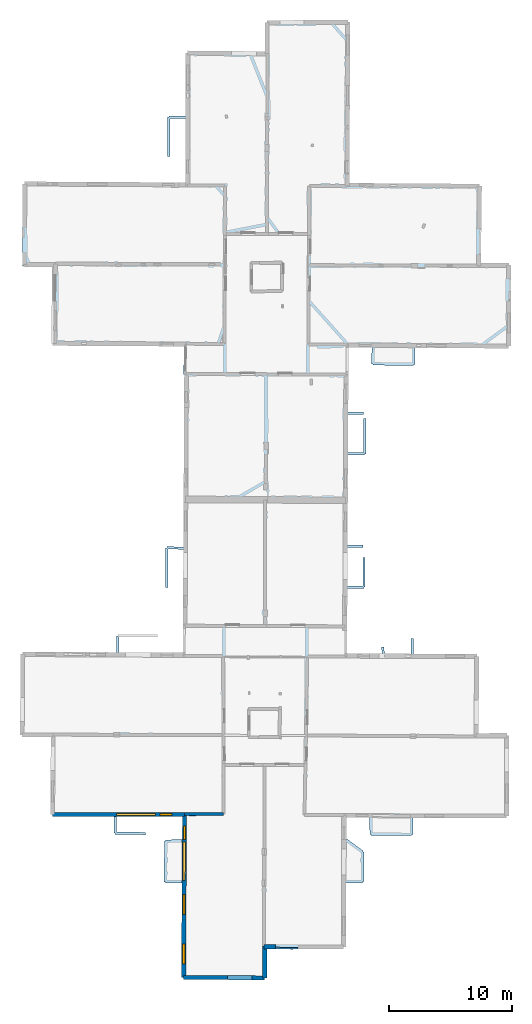
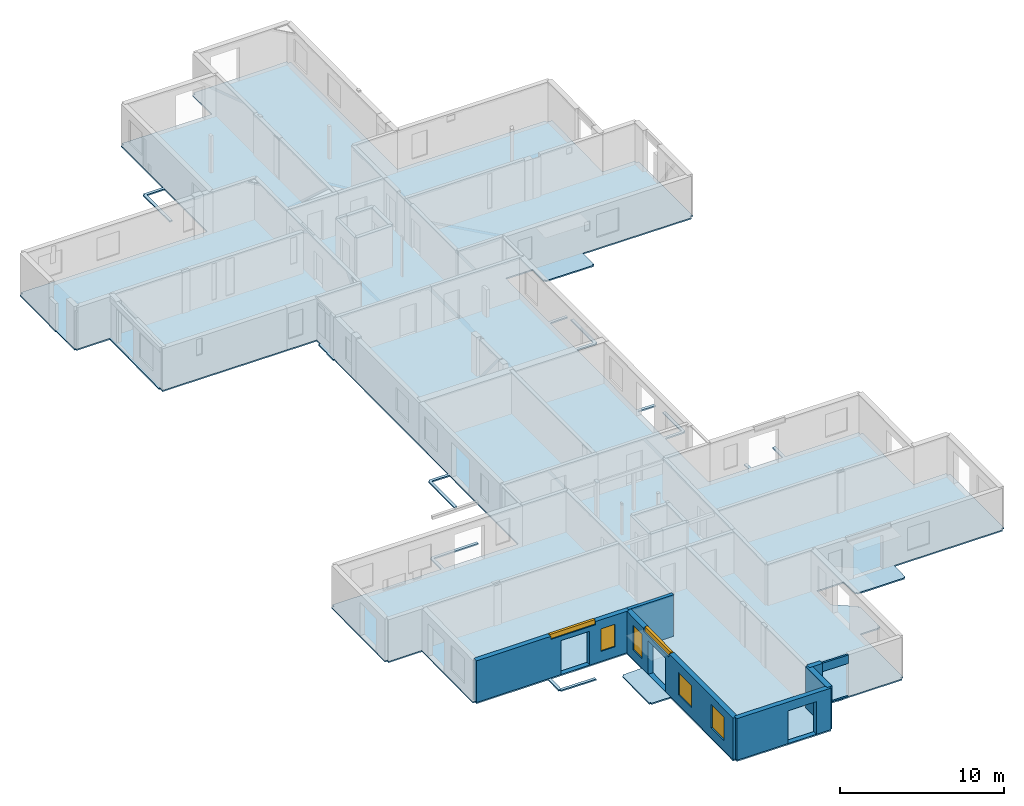
# One storey, part 3 of 17: 7 walls, 6 windows, 1 slab, 10 openings.
"""IFC2X3 building model written with IfcOpenShell, lengths in metres."""

from ifc_helpers import new_model, entity, si_unit, converted_unit, derived_unit, direction, frame, frame_2d, origin, origin_2d_with_axis, place, context, subcontext, project, spatial, polyline, rectangle, outline, extrude, clip, halfspace, source, transform, mapped, material, layer, layer_set, layer_usage, type_object, type_shapes, element, fill, save


model = new_model("IFC2X3")

# Units and contexts
model_context = context("Model", 3, precision=1e-05, world=origin(), true_north=direction((0.0, 1.0)))
body_context = subcontext(model_context, "Body", "Model", "MODEL_VIEW")
ifc_project = project(units=[si_unit("LENGTHUNIT", "METRE"), si_unit("AREAUNIT", "SQUARE_METRE"), si_unit("VOLUMEUNIT", "CUBIC_METRE"), converted_unit("PLANEANGLEUNIT", "DEGREE", entity("IfcRatioMeasure", 0.0174532925199433), si_unit("PLANEANGLEUNIT", "RADIAN"), dimensions=[0, 0, 0, 0, 0, 0, 0]), si_unit("MASSUNIT", "GRAM", prefix="KILO"), derived_unit("MASSDENSITYUNIT", [(si_unit("MASSUNIT", "GRAM", prefix="KILO"), 1), (si_unit("LENGTHUNIT", "METRE"), -3)]), derived_unit("MOMENTOFINERTIAUNIT", [(si_unit("LENGTHUNIT", "METRE"), 4)]), si_unit("TIMEUNIT", "SECOND"), si_unit("FREQUENCYUNIT", "HERTZ"), si_unit("THERMODYNAMICTEMPERATUREUNIT", "DEGREE_CELSIUS"), derived_unit("THERMALTRANSMITTANCEUNIT", [(si_unit("MASSUNIT", "GRAM", prefix="KILO"), 1), (si_unit("THERMODYNAMICTEMPERATUREUNIT", "KELVIN"), -1), (si_unit("TIMEUNIT", "SECOND"), -3)]), derived_unit("VOLUMETRICFLOWRATEUNIT", [(si_unit("LENGTHUNIT", "METRE"), 3), (si_unit("TIMEUNIT", "SECOND"), -1)]), si_unit("ELECTRICCURRENTUNIT", "AMPERE"), si_unit("ELECTRICVOLTAGEUNIT", "VOLT"), si_unit("POWERUNIT", "WATT"), si_unit("FORCEUNIT", "NEWTON", prefix="KILO"), si_unit("ILLUMINANCEUNIT", "LUX"), si_unit("LUMINOUSFLUXUNIT", "LUMEN"), si_unit("LUMINOUSINTENSITYUNIT", "CANDELA"), derived_unit("USERDEFINED", [(si_unit("MASSUNIT", "GRAM", prefix="KILO"), -1), (si_unit("LENGTHUNIT", "METRE"), -2), (si_unit("TIMEUNIT", "SECOND"), 3), (si_unit("LUMINOUSFLUXUNIT", "LUMEN"), 1)]), derived_unit("LINEARVELOCITYUNIT", [(si_unit("LENGTHUNIT", "METRE"), 1), (si_unit("TIMEUNIT", "SECOND"), -1)]), si_unit("PRESSUREUNIT", "PASCAL"), derived_unit("USERDEFINED", [(si_unit("LENGTHUNIT", "METRE"), -2), (si_unit("MASSUNIT", "GRAM", prefix="KILO"), 1), (si_unit("TIMEUNIT", "SECOND"), -2)]), derived_unit("LINEARFORCEUNIT", [(si_unit("MASSUNIT", "GRAM", prefix="KILO"), 1), (si_unit("LENGTHUNIT", "METRE"), 1), (si_unit("TIMEUNIT", "SECOND"), -2), (si_unit("LENGTHUNIT", "METRE"), -1)]), derived_unit("PLANARFORCEUNIT", [(si_unit("MASSUNIT", "GRAM", prefix="KILO"), 1), (si_unit("LENGTHUNIT", "METRE"), 1), (si_unit("TIMEUNIT", "SECOND"), -2), (si_unit("LENGTHUNIT", "METRE"), -2)])], contexts=[model_context])

# Site, building, storey
placement = place(None, origin())
site = spatial("IfcSite", under=ifc_project, at=placement, CompositionType="ELEMENT")
building = spatial("IfcBuilding", under=site, at=placement, CompositionType="ELEMENT")
storey_placement = place(placement, frame((0.0, 0.0, 12.0782108306885)))
storey = spatial("IfcBuildingStorey", under=building, at=storey_placement, Name="Level 5", CompositionType="ELEMENT", Elevation=12.0782108306885)

# Slab
ifc_material_1 = material(Name="Floor default")
ifc_layer_1 = layer(ifc_material_1, 0.1)
ifc_layer_set_1 = layer_set([ifc_layer_1], Name="Floor : 100mm")
ifc_layer_usage_1 = layer_usage(ifc_layer_set_1, "AXIS3", "POSITIVE", 0.0)
slab_type = type_object("IfcSlabType", Name="Floor : 100mm", PredefinedType="FLOOR")
slab_placement = place(storey_placement, origin())
element("IfcSlab", 1, at=slab_placement, inside=storey, type_object=slab_type, material=ifc_layer_usage_1, Name="Floor : 100mm", ObjectType="Floor : 100mm", PredefinedType="FLOOR", context=body_context, shape_type="SweptSolid", body=[
    extrude(outline(polyline([(-13.6741571426392, 19.4480590820312), (-13.5041589736938, 19.446813583374), (-13.5045537948608, 19.2818164825439), (-11.1630268096924, 19.2762126922607), (-11.2139711380005, 13.0019683837891), (-11.0389766693115, 13.0005474090576), (-11.0390968322754, 12.8305473327637), (-6.0307936668396, 12.8269901275635), (-6.05221652984619, 11.4777412414551), (-5.95222854614258, 11.4761533737183), (-5.95352220535278, 11.376163482666), (-3.47610855102539, 11.3441095352173), (-3.47352123260498, 11.544093132019), (-5.85064935684204, 11.5748491287231), (-5.83077049255371, 12.8268480300903), (-0.4891357421875, 12.8230543136597), (-0.498909950256348, 10.9644174575806), (-1.84821033477783, 10.9281635284424), (-1.84552478790283, 10.8281993865967), (-1.94552135467529, 10.8289775848389), (-1.97123622894287, 7.52532339096069), (-1.87123966217041, 7.52454519271851), (-1.87166500091553, 7.4245457649231), (-0.51755428314209, 7.41877698898315), (-0.557805061340332, -0.23591285943985), (-0.382807731628418, -0.236833453178406), (-0.383979797363281, -0.406829833984375), (6.2008695602417, -0.45224529504776), (6.20204067230225, -0.282249718904495), (6.38204097747803, -0.282319188117981), (6.38295078277588, 2.07665085792542), (8.14828205108643, 2.06885743141174), (8.14810466766357, 2.04710817337036), (8.49809169769287, 2.04424548149109), (8.49825763702393, 2.06447219848633), (8.89977550506592, 2.05944108963013), (8.8998556137085, 2.06586694717407), (12.6225538253784, 2.04991722106934), (12.6232824325562, 2.21991539001465), (12.8132829666138, 2.21951246261597), (12.8243455886841, 7.43414497375488), (14.1510801315308, 7.43108654022217), (14.1513109207153, 7.53108692169189), (14.2512922286987, 7.52911901473999), (14.2641706466675, 8.18354606628418), (14.2555894851685, 8.18371486663818), (14.2551946640015, 9.94699573516846), (14.1551961898804, 9.94697380065918), (14.2143964767456, 10.02756690979), (12.8320016860962, 11.043007850647), (12.835597038269, 12.7377643585205), (14.7113065719604, 12.7305898666382), (14.7471075057983, 11.3748683929443), (14.8470735549927, 11.3775081634521), (14.8467283248901, 11.2775077819824), (18.1309471130371, 11.2661962509155), (18.131290435791, 11.3661937713623), (18.2312850952148, 11.365122795105), (18.2457733154297, 12.7170715332031), (25.8608512878418, 12.6879453659058), (25.8614845275879, 12.8529453277588), (26.0464782714844, 12.8522891998291), (26.0697021484375, 19.399227142334), (25.8846969604492, 19.3998832702637), (25.8836364746094, 19.5998821258545), (23.5648155212402, 19.5875816345215), (23.6265411376953, 25.8390617370605), (23.4415473937988, 25.8408889770508), (23.4422302246094, 26.0308818817139), (18.3012809753418, 26.0493564605713), (18.3069648742676, 27.2925777435303), (18.1069679260254, 27.2934913635254), (18.1012840270996, 26.0500755310059), (15.9242124557495, 26.0578994750977), (15.9038305282593, 26.6042995452881), (15.70396900177, 26.5968437194824), (15.7240476608276, 26.0586223602295), (12.8908910751343, 26.0687999725342), (12.9166917800903, 31.3654937744141), (14.271746635437, 31.3605155944824), (14.2721147537231, 31.4605140686035), (14.3721170425415, 31.4606056213379), (14.3699254989624, 33.8526763916016), (14.1699247360229, 33.8524932861328), (14.1720266342163, 31.560884475708), (12.9176664352417, 31.5654926300049), (12.9329042434692, 34.6936874389648), (14.1724576950073, 34.6808815002441), (14.174521446228, 34.8808708190918), (12.9338788986206, 34.8936882019043), (12.9502191543579, 38.2479782104492), (12.9695234298706, 42.2109527587891), (14.3234243392944, 42.1769714355469), (14.3259344100952, 42.2769393920898), (14.4259328842163, 42.2764053344727), (14.4414014816284, 45.1762313842773), (14.2414045333862, 45.1772994995117), (14.2264795303345, 42.379467010498), (12.970498085022, 42.4109878540039), (12.9854497909546, 45.4803581237793), (14.2215070724487, 45.5016593933105), (14.2180624008179, 45.7016296386719), (12.986424446106, 45.6804046630859), (13.0120458602905, 50.9402236938477), (14.9055509567261, 50.9278030395508), (14.8888006210327, 49.5984764099121), (14.9887914657593, 49.5972175598145), (14.9877099990845, 49.4972267150879), (18.306640625, 49.4613342285156), (18.3077201843262, 49.5613212585449), (18.4077186584473, 49.560604095459), (18.4173698425293, 50.9047660827637), (26.022705078125, 50.8548774719238), (26.0238838195801, 51.0348625183105), (26.2088851928711, 51.0342750549316), (26.2206573486328, 54.7249374389648), (26.2223434448242, 54.7249336242676), (26.2259941101074, 56.400562286377), (26.2298812866211, 57.6184120178223), (26.0448799133301, 57.6190032958984), (26.0439682006836, 57.8040046691895), (23.7648048400879, 57.7927665710449), (23.8413238525391, 64.0483856201172), (23.5537528991699, 64.0519027709961), (23.5525932312012, 64.0626831054688), (23.4531745910645, 64.052001953125), (23.4542541503906, 64.2169876098633), (13.0820474624634, 64.2849349975586), (13.1500196456909, 77.352180480957), (12.9600229263306, 77.3531646728516), (12.959189414978, 77.5331497192383), (6.38820934295654, 77.5026626586914), (6.38904476165771, 77.3226547241211), (6.2140474319458, 77.3219985961914), (6.22282123565674, 74.9792022705078), (-0.0490074157714844, 75.0356063842773), (-0.0506267547607422, 74.8556060791016), (-0.230625152587891, 74.8558120727539), (-0.236305236816406, 69.7514953613281), (-1.58405590057373, 69.749137878418), (-1.58388137817383, 69.6491394042969), (-1.68388080596924, 69.6489105224609), (-1.67652416229248, 66.4270553588867), (-1.47652530670166, 66.4275131225586), (-1.48365306854248, 69.54931640625), (-0.236527442932129, 69.5514984130859), (-0.242335319519043, 64.3329162597656), (-13.2979316711426, 64.4030227661133), (-13.2988986968994, 64.223030090332), (-13.47389793396, 64.2231521606445), (-13.486234664917, 60.6138114929199), (-13.5225048065186, 60.6136589050293), (-13.5191774368286, 59.8286666870117), (-13.4817266464233, 59.8288269042969), (-13.4790706634521, 57.6453056335449), (-13.4691877365112, 57.6452865600586), (-13.4687404632568, 57.5673370361328), (-13.4037418365479, 57.5677108764648), (-13.4035968780518, 57.467700958252), (-11.0617952346802, 57.4711875915527), (-11.1271629333496, 51.3905143737793), (-11.0278606414795, 51.3894462585449), (-11.0295791625977, 51.0776672363281), (-0.232328414916992, 51.0181541442871), (-0.232276916503906, 50.5844917297363), (-0.362277030944824, 50.5844764709473), (-0.362153053283691, 49.5245895385742), (-0.394523620605469, 49.5246047973633), (-0.394890785217285, 48.7322616577148), (-0.330018997192383, 48.7322311401367), (-0.402862548828125, 34.7353858947754), (-1.74475383758545, 34.7481346130371), (-1.74570369720459, 34.6481399536133), (-1.84570217132568, 34.6487312316895), (-1.86463928222656, 31.4467124938965), (-1.66464328765869, 31.4455299377441), (-1.64629936218262, 34.547191619873), (-0.403903007507324, 34.5353889465332), (-0.447607040405273, 26.1376571655273), (-5.61677265167236, 26.1671772003174), (-5.62263584136963, 27.4122867584229), (-2.49050235748291, 27.4142684936523), (-2.49062919616699, 27.6142692565918), (-5.72317218780518, 27.6122245788574), (-5.72310924530029, 27.5122241973877), (-5.82310724258423, 27.5117530822754), (-5.81678104400635, 26.1683197021484), (-13.4549388885498, 26.2119388580322), (-13.4560527801514, 26.0169429779053), (-13.626049041748, 26.0181865692139), (-13.6741571426392, 19.4480590820312)])), frame((0.0, 0.0, -0.1), z_axis=(0.0, 0.0, 1.0), x_axis=(1.0, 0.0, 0.0)), (0.0, 0.0, 1.0), 0.1),
])

# Wall, openings, windows
ifc_material_2 = material(Name="Default wall")
ifc_layer_2 = layer(ifc_material_2, 0.349999994039536)
ifc_layer_set_2 = layer_set([ifc_layer_2], Name="wall_thickness_0.3500")
ifc_layer_usage_2 = layer_usage(ifc_layer_set_2, "AXIS2", "POSITIVE", -0.174999997019768)
wall_type_1 = type_object("IfcWallType", Name="wall_thickness_0.3500", PredefinedType="STANDARD", material=ifc_layer_set_2)
wall_1_placement = place(storey_placement, frame((-0.312968006058506, 13.0449057728988, 0.0), z_axis=(0.0, 0.0, 1.0), x_axis=(-0.00525819954619444, -0.999986175573209, 0.0)))
wall_1 = element("IfcWallStandardCase", 2, at=wall_1_placement, inside=storey, type_object=wall_type_1, material=ifc_layer_usage_2, Name="Wall:240", ObjectType="Wall", context=body_context, shape_type="Clipping", body=[
    clip(extrude(outline(polyline([(13.2819228498944, -0.174999997019768), (13.2819228498944, 0.174999997019768), (0.0, 0.174999997019768), (0.0, -0.174999997019768), (13.2819228498944, -0.174999997019768)])), origin(), (0.0, 0.0, 1.0), 3.09134044647217), halfspace(frame((-62.793035063667, -1.28002881080328, 5.79573318480268), z_axis=(0.000635752506920605, -0.38990025546136, 0.920856876289642), x_axis=(0.000704964527256108, 0.920855744123011, 0.389902810378011)), False)),
])
opening_1_placement = place(wall_1_placement, frame((2.85443914170069, -0.174999997019768, 0.00578975677490234)))
element("IfcOpeningElement", 3, at=opening_1_placement, cuts=wall_1, Name="Opening : 2095 x 2490 : 218", ObjectType="Opening", context=body_context, shape_type="SweptSolid", body=[
    extrude(rectangle(XDim=2.095, YDim=2.49, at=frame_2d((1.245, 1.0475), x_axis=(0.0, 1.0))), frame((0.0, 0.0, 0.0), z_axis=(0.0, 1.0, 0.0), x_axis=(0.0, 0.0, 1.0)), (0.0, 0.0, 1.0), 0.349999994039536),
])
opening_2_placement = place(wall_1_placement, frame((10.5913513008016, -0.174999997019768, 0.745789527893066)))
opening_2 = element("IfcOpeningElement", 4, at=opening_2_placement, cuts=wall_1, Name="Opening : 1590 x 1745 : 219", ObjectType="Opening", context=body_context, shape_type="SweptSolid", body=[
    extrude(rectangle(XDim=1.59, YDim=1.745, at=frame_2d((0.8725, 0.795), x_axis=(0.0, 1.0))), frame((0.0, 0.0, 0.0), z_axis=(0.0, 1.0, 0.0), x_axis=(0.0, 0.0, 1.0)), (0.0, 0.0, 1.0), 0.349999994039536),
])
opening_3_placement = place(wall_1_placement, frame((6.56135188354057, -0.174999997019768, 0.740789413452148)))
opening_3 = element("IfcOpeningElement", 5, at=opening_3_placement, cuts=wall_1, Name="Opening : 1610 x 1665 : 220", ObjectType="Opening", context=body_context, shape_type="SweptSolid", body=[
    extrude(rectangle(XDim=1.61, YDim=1.665, at=frame_2d((0.8325, 0.805), x_axis=(0.0, 1.0))), frame((0.0, 0.0, 0.0), z_axis=(0.0, 1.0, 0.0), x_axis=(0.0, 0.0, 1.0)), (0.0, 0.0, 1.0), 0.349999994039536),
])
opening_4_placement = place(wall_1_placement, frame((0.984440107194893, -0.174999997019768, 0.680789947509766)))
opening_4 = element("IfcOpeningElement", 6, at=opening_4_placement, cuts=wall_1, Name="Opening : 1090 x 1845 : 221", ObjectType="Opening", context=body_context, shape_type="SweptSolid", body=[
    extrude(rectangle(XDim=1.09, YDim=1.845, at=frame_2d((0.9225, 0.545), x_axis=(0.0, 1.0))), frame((0.0, 0.0, 0.0), z_axis=(0.0, 1.0, 0.0), x_axis=(0.0, 0.0, 1.0)), (0.0, 0.0, 1.0), 0.349999994039536),
])
opening_5_placement = place(wall_1_placement, frame((2.29135247683685, -0.174999997019768, 2.84078979492188)))
opening_5 = element("IfcOpeningElement", 7, at=opening_5_placement, cuts=wall_1, Name="Opening : 3135 x 340 : 222", ObjectType="Opening", context=body_context, shape_type="SweptSolid", body=[
    extrude(rectangle(XDim=3.135, YDim=0.34, at=frame_2d((0.17, 1.5675), x_axis=(0.0, 1.0))), frame((0.0, 0.0, 0.0), z_axis=(0.0, 1.0, 0.0), x_axis=(0.0, 0.0, 1.0)), (0.0, 0.0, 1.0), 0.349999994039536),
])
ifc_material_3 = material(Name="Window Default")
window_style_1 = type_object("IfcWindowStyle", Name="Window : 1590 x 1745mm", ConstructionType="NOTDEFINED", OperationType="NOTDEFINED", ParameterTakesPrecedence=False, Sizeable=False, material=ifc_material_3)
shared_shape_1 = source(origin(), body_context, "Body", "SweptSolid", [
    extrude(rectangle(XDim=0.174999997019768, YDim=1.59, at=origin_2d_with_axis()), frame((0.795, 0.174999997019768, 0.0), z_axis=(0.0, 0.0, 1.0), x_axis=(0.0, 1.0, 0.0)), (0.0, 0.0, 1.0), 1.745),
])
type_shapes(window_style_1, [shared_shape_1])
window_1_placement = place(opening_2_placement, origin())
window_1 = element("IfcWindow", 8, at=window_1_placement, inside=storey, type_object=window_style_1, Name="Window : 1590 x 1745mm : 117", ObjectType="Window : 1590 x 1745mm", OverallHeight=1.745, OverallWidth=1.59, context=body_context, shape_type="MappedRepresentation", body=[
    mapped(shared_shape_1, transform((0.0, 0.0, 0.0), scale=1.0)),
])
fill(opening_2, window_1)
window_style_2 = type_object("IfcWindowStyle", Name="Window : 1610 x 1665mm", ConstructionType="NOTDEFINED", OperationType="NOTDEFINED", ParameterTakesPrecedence=False, Sizeable=False, material=ifc_material_3)
shared_shape_2 = source(origin(), body_context, "Body", "SweptSolid", [
    extrude(rectangle(XDim=0.174999997019768, YDim=1.61, at=origin_2d_with_axis()), frame((0.805, 0.174999997019768, 0.0), z_axis=(0.0, 0.0, 1.0), x_axis=(0.0, 1.0, 0.0)), (0.0, 0.0, 1.0), 1.665),
])
type_shapes(window_style_2, [shared_shape_2])
window_2_placement = place(opening_3_placement, origin())
window_2 = element("IfcWindow", 9, at=window_2_placement, inside=storey, type_object=window_style_2, Name="Window : 1610 x 1665mm : 118", ObjectType="Window : 1610 x 1665mm", OverallHeight=1.665, OverallWidth=1.61, context=body_context, shape_type="MappedRepresentation", body=[
    mapped(shared_shape_2, transform((0.0, 0.0, 0.0), scale=1.0)),
])
fill(opening_3, window_2)
window_style_3 = type_object("IfcWindowStyle", Name="Window : 1090 x 1845mm", ConstructionType="NOTDEFINED", OperationType="NOTDEFINED", ParameterTakesPrecedence=False, Sizeable=False, material=ifc_material_3)
shared_shape_3 = source(origin(), body_context, "Body", "SweptSolid", [
    extrude(rectangle(XDim=0.174999997019768, YDim=1.09, at=origin_2d_with_axis()), frame((0.545, 0.174999997019768, 0.0), z_axis=(0.0, 0.0, 1.0), x_axis=(0.0, 1.0, 0.0)), (0.0, 0.0, 1.0), 1.845),
])
type_shapes(window_style_3, [shared_shape_3])
window_3_placement = place(opening_4_placement, origin())
window_3 = element("IfcWindow", 10, at=window_3_placement, inside=storey, type_object=window_style_3, Name="Window : 1090 x 1845mm : 119", ObjectType="Window : 1090 x 1845mm", OverallHeight=1.845, OverallWidth=1.09, context=body_context, shape_type="MappedRepresentation", body=[
    mapped(shared_shape_3, transform((0.0, 0.0, 0.0), scale=1.0)),
])
fill(opening_4, window_3)
window_style_4 = type_object("IfcWindowStyle", Name="Window : 3135 x 340mm", ConstructionType="NOTDEFINED", OperationType="NOTDEFINED", ParameterTakesPrecedence=False, Sizeable=False, material=ifc_material_3)
shared_shape_4 = source(origin(), body_context, "Body", "SweptSolid", [
    extrude(rectangle(XDim=0.174999997019768, YDim=3.135, at=origin_2d_with_axis()), frame((1.5675, 0.174999997019768, 0.0), z_axis=(0.0, 0.0, 1.0), x_axis=(0.0, 1.0, 0.0)), (0.0, 0.0, 1.0), 0.34),
])
type_shapes(window_style_4, [shared_shape_4])
window_4_placement = place(opening_5_placement, origin())
window_4 = element("IfcWindow", 11, at=window_4_placement, inside=storey, type_object=window_style_4, Name="Window : 3135 x 340mm : 120", ObjectType="Window : 3135 x 340mm", OverallHeight=0.34, OverallWidth=3.135, context=body_context, shape_type="MappedRepresentation", body=[
    mapped(shared_shape_4, transform((0.0, 0.0, 0.0), scale=1.0)),
])
fill(opening_5, window_4)

# Wall
ifc_layer_3 = layer(ifc_material_2, 0.239999994635582)
ifc_layer_set_3 = layer_set([ifc_layer_3], Name="wall_thickness_0.2400")
ifc_layer_usage_3 = layer_usage(ifc_layer_set_3, "AXIS2", "POSITIVE", -0.119999997317791)
wall_type_2 = type_object("IfcWallType", Name="wall_thickness_0.2400", PredefinedType="STANDARD", material=ifc_layer_set_3)
wall_2_placement = place(storey_placement, frame((-0.312968329377914, 13.0449055573293, 0.0), z_axis=(0.0, 0.0, 1.0), x_axis=(0.99999994559164, -0.000329873788827325, 0.0)))
element("IfcWallStandardCase", 12, at=wall_2_placement, inside=storey, type_object=wall_type_2, material=ifc_layer_usage_3, Name="Wall:241", ObjectType="Wall", context=body_context, shape_type="Clipping", body=[
    clip(clip(extrude(outline(polyline([(3.18013065474566, -0.119999997317791), (3.18013065474566, 0.119999997317791), (0.0, 0.119999997317791), (0.0, -0.119999997317791), (3.18013065474566, -0.119999997317791)])), origin(), (0.0, 0.0, 1.0), 3.09134044647217), halfspace(frame((-11.7222896050463, 6.54515721346767, 8.98689858314154), z_axis=(-0.00416526843737431, -0.389119214079121, 0.921177989192801), x_axis=(0.999954962088688, -0.00947654948676613, 0.000518463148508191)), False)), halfspace(frame((-0.970548142031954, 62.7985811068073, 5.79573318480268), z_axis=(-0.389898653596904, 0.00128581235215969, 0.920856876289642), x_axis=(0.920841086683937, -0.00524323698448936, 0.389902810378011)), False)),
])

# Wall, opening
ifc_layer_4 = layer(ifc_material_2, 0.129999995231628)
ifc_layer_set_4 = layer_set([ifc_layer_4], Name="wall_thickness_0.1300")
ifc_layer_usage_4 = layer_usage(ifc_layer_set_4, "AXIS2", "POSITIVE", -0.0649999976158142)
wall_type_3 = type_object("IfcWallType", Name="wall_thickness_0.1300", PredefinedType="STANDARD", material=ifc_layer_set_4)
wall_3_placement = place(storey_placement, frame((7.07752518061437, 2.14727941741162, 0.0), z_axis=(0.0, 0.0, 1.0), x_axis=(0.999921506326059, -0.0125292133282773, 0.0)))
wall_3 = element("IfcWallStandardCase", 13, at=wall_3_placement, inside=storey, type_object=wall_type_3, material=ifc_layer_usage_4, Name="Wall:369", ObjectType="Wall", context=body_context, shape_type="Clipping", body=[
    clip(clip(extrude(outline(polyline([(1.82320791436471, -0.0649999976158142), (1.82320791436471, 0.0649999976158142), (0.0, 0.0649999976158142), (0.0, -0.0649999976158142), (1.82320791436471, -0.0649999976158142)])), origin(), (0.0, 0.0, 1.0), 3.09134044647217), halfspace(frame((4.79773850755248, 75.1553497333519, 6.35864093399329), z_axis=(0.390488683604525, 0.00298895180992919, 0.920602875372374), x_axis=(-0.675252382360327, -0.678771573229149, 0.288623234499112)), False)), halfspace(frame((-8.32783650194816, -3.6083476527509, 5.87872823356804), z_axis=(0.00482725289024344, -0.392714996847692, 0.919647556882772), x_axis=(0.999924461781438, 0.0122910833981878, 0.0)), False)),
])
opening_6_placement = place(wall_3_placement, frame((-0.0350946336148622, -0.0649999976158142, 0.00578975677490234)))
element("IfcOpeningElement", 14, at=opening_6_placement, cuts=wall_3, Name="Opening : 1935 x 2460 : 301", ObjectType="Opening", context=body_context, shape_type="SweptSolid", body=[
    extrude(rectangle(XDim=1.935, YDim=2.46, at=frame_2d((1.23, 0.9675), x_axis=(0.0, 1.0))), frame((0.0, 0.0, 0.0), z_axis=(0.0, 1.0, 0.0), x_axis=(0.0, 0.0, 1.0)), (0.0, 0.0, 1.0), 0.129999995231628),
])

# Wall, openings, windows
ifc_layer_5 = layer(ifc_material_2, 0.340000003576279)
ifc_layer_set_5 = layer_set([ifc_layer_5], Name="wall_thickness_0.3400")
ifc_layer_usage_5 = layer_usage(ifc_layer_set_5, "AXIS2", "POSITIVE", -0.170000001788139)
wall_type_4 = type_object("IfcWallType", Name="wall_thickness_0.3400", PredefinedType="STANDARD", material=ifc_layer_set_5)
wall_4_placement = place(storey_placement, frame((-11.0389760910136, 13.000547291674, 0.0), z_axis=(0.0, 0.0, 1.0), x_axis=(0.999999747772739, -0.000710249574828976, 0.0)))
wall_4 = element("IfcWallStandardCase", 15, at=wall_4_placement, inside=storey, type_object=wall_type_4, material=ifc_layer_usage_5, Name="Wall:233", ObjectType="Wall", context=body_context, shape_type="Clipping", body=[
    clip(extrude(outline(polyline([(10.7257374160167, -0.170000001788139), (10.7257374160167, 0.170000001788139), (0.0, 0.170000001788139), (0.0, -0.170000001788139), (10.7257374160167, -0.170000001788139)])), origin(), (0.0, 0.0, 1.0), 3.09134044647217), halfspace(frame((-0.998804825828467, 6.59267426124677, 8.98689858314154), z_axis=(-0.00401725659180406, -0.389120770296554, 0.921177989192801), x_axis=(0.999958494399439, -0.00909619010197678, 0.000518463148508191)), False)),
])
opening_7_placement = place(wall_4_placement, frame((5.92135912574465, -0.170000001788139, 0.00578975677490234)))
element("IfcOpeningElement", 16, at=opening_7_placement, cuts=wall_4, Name="Opening : 2020 x 2520 : 205", ObjectType="Opening", context=body_context, shape_type="SweptSolid", body=[
    extrude(rectangle(XDim=2.02, YDim=2.52, at=frame_2d((1.26, 1.01), x_axis=(0.0, 1.0))), frame((0.0, 0.0, 0.0), z_axis=(0.0, 1.0, 0.0), x_axis=(0.0, 0.0, 1.0)), (0.0, 0.0, 1.0), 0.340000003576279),
])
opening_8_placement = place(wall_4_placement, frame((5.20832765531246, -0.170000001788139, 2.86078929901123)))
opening_8 = element("IfcOpeningElement", 17, at=opening_8_placement, cuts=wall_4, Name="Opening : 3155 x 320 : 206", ObjectType="Opening", context=body_context, shape_type="SweptSolid", body=[
    extrude(rectangle(XDim=3.155, YDim=0.32, at=frame_2d((0.16, 1.5775), x_axis=(0.0, 1.0))), frame((0.0, 0.0, 0.0), z_axis=(0.0, 1.0, 0.0), x_axis=(0.0, 0.0, 1.0)), (0.0, 0.0, 1.0), 0.340000003576279),
])
opening_9_placement = place(wall_4_placement, frame((8.73859482921568, -0.170000001788139, 0.740789413452148)))
opening_9 = element("IfcOpeningElement", 18, at=opening_9_placement, cuts=wall_4, Name="Opening : 980 x 1680 : 207", ObjectType="Opening", context=body_context, shape_type="SweptSolid", body=[
    extrude(rectangle(XDim=0.98, YDim=1.68, at=frame_2d((0.84, 0.49), x_axis=(0.0, 1.0))), frame((0.0, 0.0, 0.0), z_axis=(0.0, 1.0, 0.0), x_axis=(0.0, 0.0, 1.0)), (0.0, 0.0, 1.0), 0.340000003576279),
])
window_style_5 = type_object("IfcWindowStyle", Name="Window : 3155 x 320mm", ConstructionType="NOTDEFINED", OperationType="NOTDEFINED", ParameterTakesPrecedence=False, Sizeable=False, material=ifc_material_3)
shared_shape_5 = source(origin(), body_context, "Body", "SweptSolid", [
    extrude(rectangle(XDim=0.170000001788139, YDim=3.155, at=origin_2d_with_axis()), frame((1.5775, 0.170000001788139, 0.0), z_axis=(0.0, 0.0, 1.0), x_axis=(0.0, 1.0, 0.0)), (0.0, 0.0, 1.0), 0.32),
])
type_shapes(window_style_5, [shared_shape_5])
window_5_placement = place(opening_8_placement, origin())
window_5 = element("IfcWindow", 19, at=window_5_placement, inside=storey, type_object=window_style_5, Name="Window : 3155 x 320mm : 109", ObjectType="Window : 3155 x 320mm", OverallHeight=0.32, OverallWidth=3.155, context=body_context, shape_type="MappedRepresentation", body=[
    mapped(shared_shape_5, transform((0.0, 0.0, 0.0), scale=1.0)),
])
fill(opening_8, window_5)
window_style_6 = type_object("IfcWindowStyle", Name="Window : 980 x 1680mm", ConstructionType="NOTDEFINED", OperationType="NOTDEFINED", ParameterTakesPrecedence=False, Sizeable=False, material=ifc_material_3)
shared_shape_6 = source(origin(), body_context, "Body", "SweptSolid", [
    extrude(rectangle(XDim=0.170000001788139, YDim=0.98, at=origin_2d_with_axis()), frame((0.49, 0.170000001788139, 0.0), z_axis=(0.0, 0.0, 1.0), x_axis=(0.0, 1.0, 0.0)), (0.0, 0.0, 1.0), 1.68),
])
type_shapes(window_style_6, [shared_shape_6])
window_6_placement = place(opening_9_placement, origin())
window_6 = element("IfcWindow", 20, at=window_6_placement, inside=storey, type_object=window_style_6, Name="Window : 980 x 1680mm : 110", ObjectType="Window : 980 x 1680mm", OverallHeight=1.68, OverallWidth=0.98, context=body_context, shape_type="MappedRepresentation", body=[
    mapped(shared_shape_6, transform((0.0, 0.0, 0.0), scale=1.0)),
])
fill(opening_9, window_6)

# Wall, opening
wall_5_placement = place(storey_placement, frame((-0.382807579779065, -0.236833875341562, 0.0), z_axis=(0.0, 0.0, 1.0), x_axis=(0.999976216795389, -0.00689679951732038, 0.0)))
wall_5 = element("IfcWallStandardCase", 21, at=wall_5_placement, inside=storey, type_object=wall_type_4, material=ifc_layer_usage_5, Name="Wall:307", ObjectType="Wall", context=body_context, shape_type="Clipping", body=[
    clip(extrude(outline(polyline([(6.58500525487659, -0.170000001788139), (6.58500525487659, 0.170000001788139), (0.0, 0.170000001788139), (0.0, -0.170000001788139), (6.58500525487659, -0.170000001788139)])), origin(), (0.0, 0.0, 1.0), 3.09134044647217), halfspace(frame((-0.904316399939108, -1.12587355322936, 5.87872823356804), z_axis=(0.00261514736575071, -0.392735957258569, 0.919647556882772), x_axis=(0.999977830899623, 0.00665865671774742, 0.0)), False)),
])
opening_10_placement = place(wall_5_placement, frame((3.5675093825737, -0.170000001788139, 0.00578975677490234)))
element("IfcOpeningElement", 22, at=opening_10_placement, cuts=wall_5, Name="Opening : 1995 x 2435 : 254", ObjectType="Opening", context=body_context, shape_type="SweptSolid", body=[
    extrude(rectangle(XDim=1.995, YDim=2.435, at=frame_2d((1.2175, 0.9975), x_axis=(0.0, 1.0))), frame((0.0, 0.0, 0.0), z_axis=(0.0, 1.0, 0.0), x_axis=(0.0, 0.0, 1.0)), (0.0, 0.0, 1.0), 0.340000003576279),
])

# Walls
wall_6_placement = place(storey_placement, frame((6.14901517198323, 2.24765471056801, 0.0), z_axis=(0.0, 0.0, 1.0), x_axis=(0.999990819786181, -0.00428489712385137, 0.0)))
element("IfcWallStandardCase", 23, at=wall_6_placement, inside=storey, type_object=wall_type_4, material=ifc_layer_usage_5, Name="Wall:331", ObjectType="Wall", context=body_context, shape_type="Clipping", body=[
    clip(clip(extrude(outline(polyline([(0.928324638551683, -0.170000001788139), (0.928324638551683, 0.170000001788139), (0.0, 0.170000001788139), (0.0, -0.170000001788139), (0.928324638551683, -0.170000001788139)])), origin(), (0.0, 0.0, 1.0), 3.09134044647217), halfspace(frame((6.34612813117127, 75.0168445082736, 6.35864093399329), z_axis=(0.390500054678053, -0.000230548378368497, 0.920602875372374), x_axis=(-0.680825590411776, -0.673181360368606, 0.288623234499112)), False)), halfspace(frame((-7.42837104072176, -3.63596165795999, 5.87872823356804), z_axis=(0.00158933530095031, -0.392741448198239, 0.919647556882772), x_axis=(0.99999181186997, 0.00404675092066799, 0.0)), False)),
])
ifc_layer_6 = layer(ifc_material_2, 0.360000014305115)
ifc_layer_set_6 = layer_set([ifc_layer_6], Name="wall_thickness_0.3600")
ifc_layer_usage_6 = layer_usage(ifc_layer_set_6, "AXIS2", "POSITIVE", -0.180000007152557)
wall_type_5 = type_object("IfcWallType", Name="wall_thickness_0.3600", PredefinedType="STANDARD", material=ifc_layer_set_6)
wall_7_placement = place(storey_placement, frame((6.20304281860459, 2.31411943942125, 0.0), z_axis=(0.0, 0.0, 1.0), x_axis=(-0.000386043576622349, -0.999999925485176, 0.0)))
element("IfcWallStandardCase", 24, at=wall_7_placement, inside=storey, type_object=wall_type_5, material=ifc_layer_usage_6, Name="Wall:263", ObjectType="Wall", context=body_context, shape_type="Clipping", body=[
    clip(extrude(outline(polyline([(2.59636934076873, -0.180000007152557), (2.59636934076873, 0.180000007152557), (0.0, 0.180000007152557), (0.0, -0.180000007152557), (2.59636934076873, -0.180000007152557)])), origin(), (0.0, 0.0, 1.0), 3.09134044647217), halfspace(frame((3.67345744876569, -7.496492658907, 5.87872823356804), z_axis=(0.392744659729698, 5.80805661798161e-05, 0.919647556882772), x_axis=(-0.000147895315493452, 0.999999989063488, 0.0)), False)),
])

save(model, "model.ifc")
